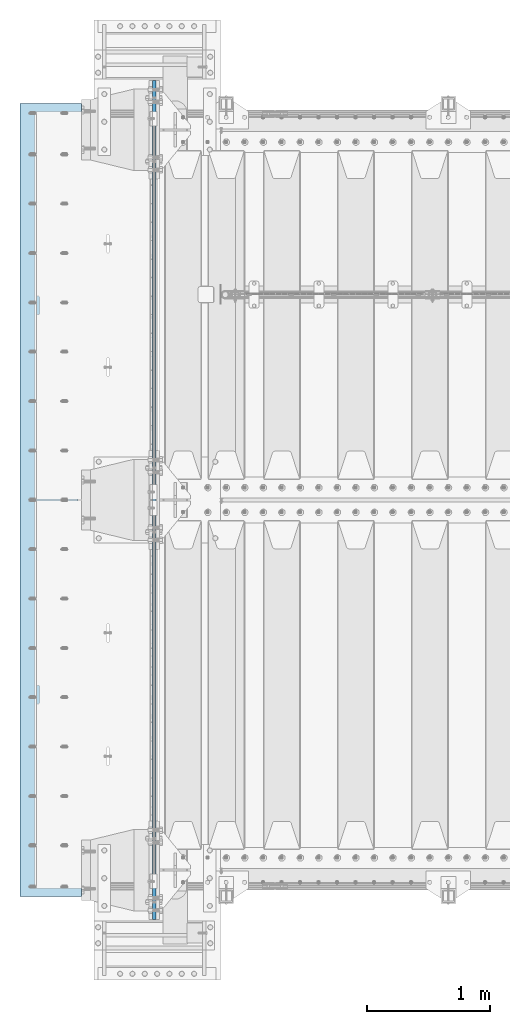
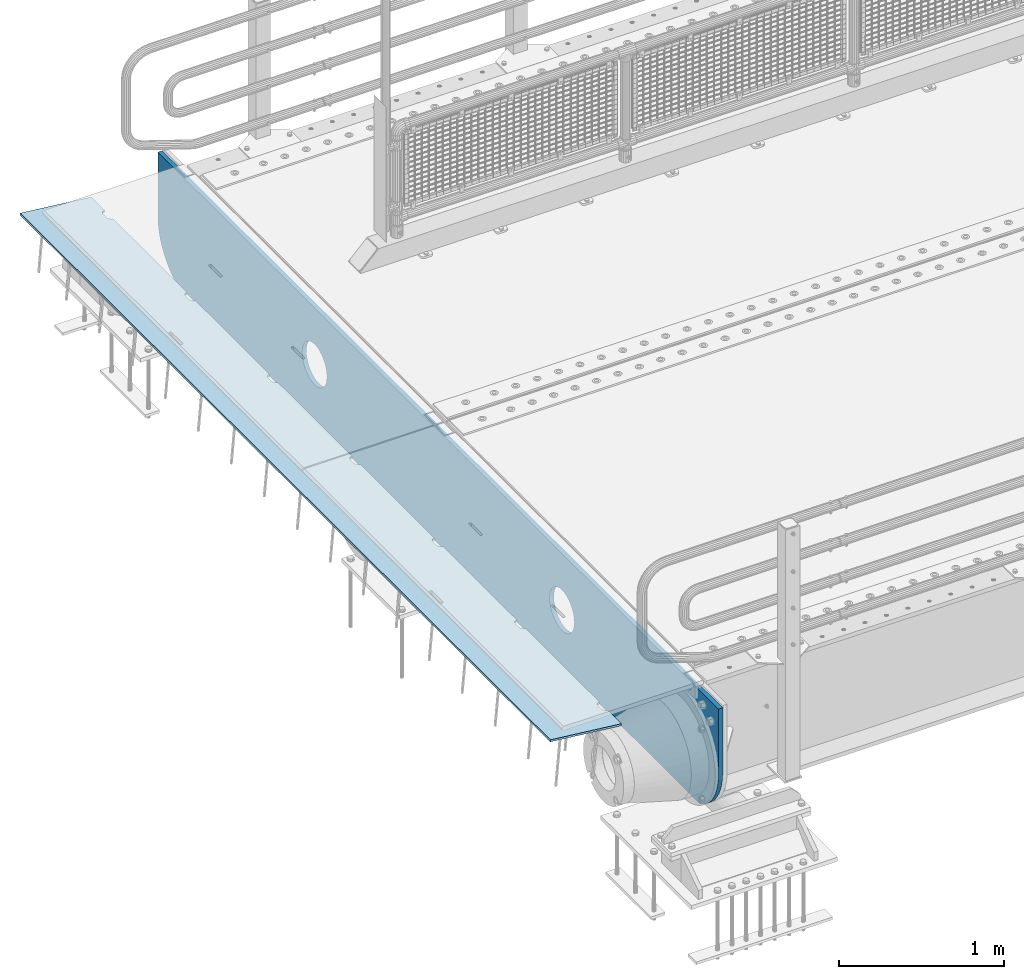
# One storey, part 162 of 208: 2 plates.
"""IFC2X3 building model written with IfcOpenShell, lengths in millimetres."""

from ifc_helpers import new_model, si_unit, frame, origin_with_axes, place, context, subcontext, project, spatial, faceted_brep, material, type_object, element, save


model = new_model("IFC2X3")

# Units and contexts
model_context = context("Model", 3, precision=1e-05, world=origin_with_axes())
body_context = subcontext(model_context, "Body", "Model", "MODEL_VIEW")
ifc_project = project(units=[si_unit("LENGTHUNIT", "METRE", prefix="MILLI"), si_unit("AREAUNIT", "SQUARE_METRE"), si_unit("VOLUMEUNIT", "CUBIC_METRE"), si_unit("MASSUNIT", "GRAM", prefix="KILO"), si_unit("TIMEUNIT", "SECOND"), si_unit("PLANEANGLEUNIT", "RADIAN"), si_unit("SOLIDANGLEUNIT", "STERADIAN"), si_unit("THERMODYNAMICTEMPERATUREUNIT", "DEGREE_CELSIUS"), si_unit("LUMINOUSINTENSITYUNIT", "LUMEN")], contexts=[model_context])

# Site, building, storey
site_placement = place(None, origin_with_axes())
site = spatial("IfcSite", under=ifc_project, at=site_placement, CompositionType="ELEMENT")
building_placement = place(site_placement, origin_with_axes())
building = spatial("IfcBuilding", under=site, at=building_placement, Name="Standard", CompositionType="ELEMENT")
storey_placement = place(building_placement, origin_with_axes())
storey = spatial("IfcBuildingStorey", under=building, at=storey_placement, Name="Undefined", CompositionType="ELEMENT", Elevation=0.0)

# Plates
ifc_material = material(Name="STEEL/S355N")
plate_type_1 = type_object("IfcPlateType", PredefinedType="NOTDEFINED")
plate_1_placement = place(storey_placement, frame((-42485.0, -400.0, -35.999983103574), z_axis=(0.0, 1.0, 0.0), x_axis=(0.0, 0.0, -1.0)))
element("IfcPlate", 1, at=plate_1_placement, inside=storey, type_object=plate_type_1, material=ifc_material, context=body_context, shape_type="Brep", body=[
    faceted_brep([(449.263580019493, -15.0, 2047.11778936592), (449.263580019493, 15.0000000000073, 2047.11778936592), (477.402546520622, 15.0000000000073, 2038.58192701329), (477.402546520622, -15.0, 2038.58192701329), (503.33556653563, 15.0000000000073, 2024.72043882638), (503.33556653563, -15.0, 2024.72043882638), (526.066048648745, 15.0000000000073, 2006.0660140226), (526.066048648745, -15.0, 2006.0660140226), (544.720473179762, 15.0000000000073, 1983.33553168563), (544.720473179762, -15.0, 1983.33553168563), (558.581961055475, 15.0000000000073, 1957.40251150429), (558.581961055475, -15.0, 1957.40251150429), (567.117823070433, 15.0000000000073, 1929.26354490073), (567.117823070433, -15.0, 1929.26354490073), (570.000030834367, 15.0000000000073, 1899.99999658102), (570.000030834367, -15.0, 1899.99999658102), (567.11782271927, 15.0000000000073, 1870.73644829589), (567.11782271927, -15.0, 1870.73644829589), (558.581960366645, 15.0000000000073, 1842.59748179476), (558.581960366645, -15.0, 1842.59748179476), (544.720472179735, 15.0000000000073, 1816.66446177975), (544.720472179735, -15.0, 1816.66446177975), (526.066047375953, 15.0000000000073, 1793.93397966664), (526.066047375953, -15.0, 1793.93397966664), (503.335565038984, 15.0000000000073, 1775.27955513562), (503.335565038984, -15.0, 1775.27955513562), (477.402544857639, 15.0000000000073, 1761.41806725991), (477.402544857639, -15.0, 1761.41806725991), (449.263578254079, 15.0000000000073, 1752.88220524495), (449.263578254079, -15.0, 1752.88220524495), (420.000029934367, 15.0000000000073, 1749.99999748102), (420.000029934367, -15.0, 1749.99999748102), (390.736481649241, 15.0000000000073, 1752.88220559611), (390.736481649241, -15.0, 1752.88220559611), (362.597515148112, 15.0000000000073, 1761.41806794874), (362.597515148112, -15.0, 1761.41806794874), (336.664495133104, 15.0000000000073, 1775.27955613565), (336.664495133104, -15.0, 1775.27955613565), (313.934013019988, 15.0000000000073, 1793.93398093943), (313.934013019988, -15.0, 1793.93398093943), (295.279588488972, 15.0000000000073, 1816.6644632764), (295.279588488972, -15.0, 1816.6644632764), (281.418100613259, 15.0000000000073, 1842.59748345774), (281.418100613259, -15.0, 1842.59748345774), (272.882238598301, 15.0000000000073, 1870.7364500613), (272.882238598301, -15.0, 1870.7364500613), (270.000030834367, 15.0000000000073, 1899.99999838101), (270.000030834367, -15.0, 1899.99999838101), (272.882238949463, 15.0000000000073, 1929.26354666614), (272.882238949463, -15.0, 1929.26354666614), (281.418101302089, 15.0000000000073, 1957.40251316727), (281.418101302089, -15.0, 1957.40251316727), (295.279589488998, 15.0000000000073, 1983.33553318228), (295.279589488998, -15.0, 1983.33553318228), (313.934014292781, 15.0000000000073, 2006.06601529539), (313.934014292781, -15.0, 2006.06601529539), (336.664496629749, 15.0000000000073, 2024.72043982641), (336.664496629749, -15.0, 2024.72043982641), (362.597516811095, 15.0000000000073, 2038.58192770212), (362.597516811095, -15.0, 2038.58192770212), (390.736483414654, 15.0000000000073, 2047.11778971708), (390.736483414654, -15.0, 2047.11778971708), (420.000031734367, 15.0000000000073, 2049.99999748101), (420.000031734367, -15.0, 2049.99999748101), (-9.73069049337028e-07, 15.0, 6800.0), (-9.73069049337028e-07, -15.0, 6800.0), (479.000057686541, -15.0, 6799.9999971271), (479.000057656483, 15.0, 6800.0), (0.0, -15.0, 0.0), (0.0, 15.0, 0.0), (478.999999999949, 15.0, -7.38964445190504e-13), (478.999999999949, -15.0, -7.38964445190504e-13), (527.214672102027, 15.0000000000073, 2.91645036077398), (527.214672102027, -15.0, 2.91645036077398), (574.726265714921, 15.0000000000073, 11.6232730295747), (574.726265714921, -15.0, 11.6232730295747), (620.841954816912, 15.0000000000073, 25.9935029258299), (620.841954816912, -15.0, 25.9935029258299), (664.889268817405, 15.0000000000073, 45.8175897387123), (664.889268817405, -15.0, 45.8175897387123), (706.22589869236, 15.0000000000073, 70.8064536425332), (706.22589869236, -15.0, 70.8064536425332), (744.249063296216, 15.0000000000073, 100.595700731555), (744.249063296216, -15.0, 100.595700731555), (778.404299268338, 15.0000000000073, 134.750936703678), (778.404299268338, -15.0, 134.750936703678), (808.19354635736, 15.0000000000073, 172.774101307533), (808.19354635736, -15.0, 172.774101307533), (833.182410261182, 15.0000000000073, 214.110731182489), (833.182410261182, -15.0, 214.110731182489), (838.999997962172, -15.0, 227.03688080086), (838.999997962172, 15.0, 227.036880800861), (838.99994100267, 15.0, 6572.96326468628), (838.99994100267, -15.0, 6572.96326475294), (833.182425765763, 14.9999999999927, 6585.88925446606), (833.182425795763, -14.9999999999927, 6585.88925446606), (808.193562534776, 14.9999999999927, 6627.22588611692), (808.193562564776, -14.9999999999927, 6627.22588611692), (778.404315788038, 14.9999999999927, 6665.24905247741), (778.404315818038, -14.9999999999927, 6665.24905247741), (744.24907984373, 14.9999999999927, 6699.40429013438), (744.24907987373, -14.9999999999927, 6699.40429013438), (706.225914976979, 14.9999999999927, 6729.19353878774), (706.225915006979, -14.9999999999927, 6729.19353878774), (664.889284579151, 14.9999999999927, 6754.18240409149), (664.889284609151, -14.9999999999927, 6754.18240409149), (620.841969832677, 14.9999999999927, 6774.00649210181), (620.841969862677, -14.9999999999927, 6774.00649210181), (574.726279803637, 14.9999999999927, 6788.37672296152), (574.726279833637, -14.9999999999927, 6788.37672296152), (527.214685128769, 14.9999999999927, 6797.08354633558), (527.214685158768, -14.9999999999927, 6797.08354633558), (477.402561971195, -15.0, 5038.58192701329), (503.335581986203, -15.0, 5024.72043882638), (526.066064099318, -15.0, 5006.0660140226), (544.720488630335, -15.0, 4983.33553168563), (558.581976506048, -15.0, 4957.40251150429), (567.117838521005, -15.0, 4929.26354490073), (570.00004628494, -15.0, 4899.99999658101), (567.117838169843, -15.0, 4870.73644829589), (558.581975817217, -15.0, 4842.59748179476), (544.720487630308, -15.0, 4816.66446177975), (526.066062826526, -15.0, 4793.93397966664), (503.335580489557, -15.0, 4775.27955513562), (477.402560308211, -15.0, 4761.41806725991), (449.263593704652, -15.0, 4752.88220524495), (420.00004538494, -15.0, 4749.99999748101), (390.736497099814, -15.0, 4752.88220559611), (362.597530598685, -15.0, 4761.41806794874), (336.664510583677, -15.0, 4775.27955613565), (313.934028470561, -15.0, 4793.93398093943), (295.279603939545, -15.0, 4816.6644632764), (281.418116063832, -15.0, 4842.59748345774), (272.882254048874, -15.0, 4870.7364500613), (270.00004628494, -15.0, 4899.99999838101), (272.882254400036, -15.0, 4929.26354666614), (281.418116752662, -15.0, 4957.40251316727), (295.279604939571, -15.0, 4983.33553318228), (313.934029743354, -15.0, 5006.06601529539), (336.664512080322, -15.0, 5024.72043982641), (362.597532261668, -15.0, 5038.58192770212), (390.736498865227, -15.0, 5047.11778971708), (420.00004718494, -15.0, 5049.99999748101), (449.263595470066, -15.0, 5047.11778936592), (362.597532261668, 15.0, 5038.58192770212), (390.736498865227, 15.0, 5047.11778971708), (336.664512080322, 15.0, 5024.72043982641), (313.934029743354, 15.0, 5006.06601529539), (295.279604939571, 15.0, 4983.33553318228), (281.418116752662, 15.0, 4957.40251316727), (272.882254400036, 15.0, 4929.26354666614), (270.00004628494, 15.0, 4899.99999838101), (272.882254048874, 15.0, 4870.7364500613), (281.418116063832, 15.0, 4842.59748345774), (295.279603939545, 15.0, 4816.6644632764), (313.934028470561, 15.0, 4793.93398093943), (336.664510583677, 15.0, 4775.27955613565), (362.597530598685, 15.0, 4761.41806794874), (390.736497099814, 15.0, 4752.88220559611), (420.00004538494, 15.0, 4749.99999748101), (449.263593704652, 15.0, 4752.88220524495), (477.402560308211, 15.0, 4761.41806725991), (503.335580489557, 15.0, 4775.27955513562), (526.066062826526, 15.0, 4793.93397966664), (544.720487630308, 15.0, 4816.66446177975), (558.581975817217, 15.0, 4842.59748179476), (567.117838169843, 15.0, 4870.73644829589), (570.00004628494, 15.0, 4899.99999658101), (567.117838521005, 15.0, 4929.26354490073), (558.581976506048, 15.0, 4957.40251150429), (544.720488630335, 15.0, 4983.33553168563), (526.066064099318, 15.0, 5006.0660140226), (503.335581986203, 15.0, 5024.72043882638), (477.402561971195, 15.0, 5038.58192701329), (449.263595470066, 15.0, 5047.11778936592), (420.00004718494, 15.0, 5049.99999748101)], [[[0, 1, 2, 3]], [[3, 2, 4, 5]], [[5, 4, 6, 7]], [[7, 6, 8, 9]], [[9, 8, 10, 11]], [[11, 10, 12, 13]], [[13, 12, 14, 15]], [[15, 14, 16, 17]], [[17, 16, 18, 19]], [[19, 18, 20, 21]], [[21, 20, 22, 23]], [[23, 22, 24, 25]], [[25, 24, 26, 27]], [[27, 26, 28, 29]], [[29, 28, 30, 31]], [[31, 30, 32, 33]], [[33, 32, 34, 35]], [[35, 34, 36, 37]], [[37, 36, 38, 39]], [[39, 38, 40, 41]], [[41, 40, 42, 43]], [[43, 42, 44, 45]], [[45, 44, 46, 47]], [[47, 46, 48, 49]], [[49, 48, 50, 51]], [[51, 50, 52, 53]], [[53, 52, 54, 55]], [[55, 54, 56, 57]], [[57, 56, 58, 59]], [[59, 58, 60, 61]], [[61, 60, 62, 63]], [[63, 62, 1, 0]], [[64, 65, 66, 67]], [[68, 65, 64, 69]], [[68, 69, 70, 71]], [[71, 70, 72, 73]], [[73, 72, 74, 75]], [[75, 74, 76, 77]], [[77, 76, 78, 79]], [[79, 78, 80, 81]], [[81, 80, 82, 83]], [[83, 82, 84, 85]], [[85, 84, 86, 87]], [[87, 86, 88, 89]], [[90, 89, 88, 91]], [[90, 91, 92, 93]], [[93, 92, 94, 95]], [[95, 94, 96, 97]], [[97, 96, 98, 99]], [[99, 98, 100, 101]], [[101, 100, 102, 103]], [[103, 102, 104, 105]], [[105, 104, 106, 107]], [[107, 106, 108, 109]], [[109, 108, 110, 111]], [[66, 111, 110, 67]], [[65, 68, 71, 73, 75, 77, 79, 81, 83, 85, 87, 89, 90, 93, 95, 97, 99, 101, 103, 105, 107, 109, 111, 66], [3, 5, 7, 9, 11, 13, 15, 17, 19, 21, 23, 25, 27, 29, 31, 33, 35, 37, 39, 41, 43, 45, 47, 49, 51, 53, 55, 57, 59, 61, 63, 0], [112, 113, 114, 115, 116, 117, 118, 119, 120, 121, 122, 123, 124, 125, 126, 127, 128, 129, 130, 131, 132, 133, 134, 135, 136, 137, 138, 139, 140, 141, 142, 143]], [[140, 144, 145, 141]], [[139, 146, 144, 140]], [[138, 147, 146, 139]], [[137, 148, 147, 138]], [[136, 149, 148, 137]], [[135, 150, 149, 136]], [[134, 151, 150, 135]], [[133, 152, 151, 134]], [[132, 153, 152, 133]], [[131, 154, 153, 132]], [[130, 155, 154, 131]], [[129, 156, 155, 130]], [[128, 157, 156, 129]], [[127, 158, 157, 128]], [[126, 159, 158, 127]], [[125, 160, 159, 126]], [[124, 161, 160, 125]], [[123, 162, 161, 124]], [[122, 163, 162, 123]], [[121, 164, 163, 122]], [[120, 165, 164, 121]], [[119, 166, 165, 120]], [[118, 167, 166, 119]], [[117, 168, 167, 118]], [[116, 169, 168, 117]], [[115, 170, 169, 116]], [[114, 171, 170, 115]], [[113, 172, 171, 114]], [[112, 173, 172, 113]], [[143, 174, 173, 112]], [[142, 175, 174, 143]], [[141, 145, 175, 142]], [[108, 106, 104, 102, 100, 98, 96, 94, 92, 91, 88, 86, 84, 82, 80, 78, 76, 74, 72, 70, 69, 64, 67, 110], [58, 56, 54, 52, 50, 48, 46, 44, 42, 40, 38, 36, 34, 32, 30, 28, 26, 24, 22, 20, 18, 16, 14, 12, 10, 8, 6, 4, 2, 1, 62, 60], [144, 146, 147, 148, 149, 150, 151, 152, 153, 154, 155, 156, 157, 158, 159, 160, 161, 162, 163, 164, 165, 166, 167, 168, 169, 170, 171, 172, 173, 174, 175, 145]]]),
])
plate_type_2 = type_object("IfcPlateType", PredefinedType="NOTDEFINED")
plate_2_placement = place(storey_placement, frame((-43074.1812549702, -214.999999999995, -62.544823504668), z_axis=(-0.994023532708189, -3.99999998872671e-09, 0.109166003967953), x_axis=(0.0, 1.0, 0.0)))
element("IfcPlate", 2, at=plate_2_placement, inside=storey, type_object=plate_type_2, material=ifc_material, context=body_context, shape_type="Brep", body=[
    faceted_brep([(6164.99999999665, -7.49999999999909, 7.33479246264324e-05), (6165.00000000327, 7.50000000000091, -2.18278728425503e-11), (6165.45576743374, 7.50000000000091, 5.20976320983755), (6165.45576742719, -7.49999999999909, 5.20976320983755), (6166.80922142074, 7.50000000000091, 10.2609221742096), (6166.80922141419, -7.49999999999727, 10.2609221742168), (6169.01923794974, 7.5, 15.0003178656625), (6169.01923794319, -7.49999999999818, 15.0003178656625), (6172.01866678684, 7.50000000000091, 19.2839461443364), (6172.01866678029, -7.49999999999818, 19.2839461443364), (6175.7163718046, 7.50000000000091, 22.9816511325989), (6175.71637179805, -7.49999999999727, 22.9816511325989), (6180.00000010719, 7.50000000000091, 25.9810799355328), (6180.00000010064, -7.49999999999818, 25.98107993554), (6184.73939581626, 7.50000000000091, 28.1910964267299), (6184.73939580971, -7.49999999999727, 28.1910964267299), (6189.79055479144, 7.50000000000091, 29.5445503734445), (6189.79055478489, -7.49999999999727, 29.5445503734445), (6195.00000012327, 7.50000000000091, 30.0003177623585), (6195.00000011672, -7.49999999999727, 30.0003177623657), (6235.00000012327, 7.50000000000182, 30.0003176033133), (6235.00000011672, -7.49999999999636, 30.0003176033133), (6240.20944545146, 7.5, 29.54455017297), (6240.20944544491, -7.49999999999818, 29.54455017297), (6245.2606044158, 7.50000000000091, 28.1910961860995), (6245.26060440926, -7.49999999999727, 28.1910961860922), (6250.00000010719, 7.5, 25.9810796571983), (6250.00000010064, -7.49999999999818, 25.9810796572056), (6254.28362838579, 7.50000000000091, 22.9816508202057), (6254.28362837924, -7.49999999999818, 22.981650820213), (6257.98133337397, 7.50000000000091, 19.283945802541), (6257.98133336743, -7.49999999999727, 19.2839458025337), (6260.98076217681, 7.50000000000091, 15.0003175000093), (6260.98076217025, -7.49999999999818, 15.0003175000093), (6263.19077866789, 7.50000000000091, 10.2609217909994), (6263.19077866134, -7.49999999999727, 10.2609217909921), (6264.54423261448, 7.50000000000091, 5.20976281585172), (6264.54423260793, -7.49999999999818, 5.20976281585172), (6264.99999999672, -7.5, 0.000317484031256754), (6265.00000000327, 7.5, -2.18278728425503e-11), (5264.99999999672, -7.5, 0.000322454179695342), (5264.54423260793, -7.50000000000182, 5.20976778599288), (5264.54423261448, 7.50000000000364, 5.20976778599288), (5265.00000000327, 7.50000000000091, -2.18278728425503e-11), (5263.19077866134, -7.5, 10.2609267611406), (5263.19077866789, 7.50000000000273, 10.2609267611333), (5260.98076217025, -7.50000000000091, 15.000322470165), (5260.98076217681, 7.50000000000273, 15.0003224701577), (5257.98133336743, -7.50000000000091, 19.2839507726821), (5257.98133337397, 7.50000000000364, 19.2839507726749), (5254.28362837924, -7.5, 22.9816557903541), (5254.28362838579, 7.50000000000273, 22.9816557903541), (5250.00000010064, -7.50000000000182, 25.9810846273467), (5250.00000010719, 7.50000000000364, 25.9810846273467), (5245.26060440926, -7.50000000000091, 28.1911011562406), (5245.2606044158, 7.50000000000273, 28.1911011562333), (5240.20944544491, -7.5, 29.5445551431185), (5240.20944545146, 7.50000000000364, 29.5445551431112), (5235.00000011672, -7.49999999999909, 30.0003225734617), (5235.00000012327, 7.50000000000364, 30.0003225734545), (5195.00000011672, -7.5, 30.0003227324996), (5195.00000012327, 7.50000000000273, 30.0003227324996), (5189.79055478489, -7.5, 29.5445553435857), (5189.79055479144, 7.50000000000364, 29.5445553435857), (5184.73939580971, -7.50000000000091, 28.1911013968711), (5184.73939581626, 7.50000000000273, 28.1911013968711), (5180.00000010064, -7.50000000000182, 25.9810849056812), (5180.00000010719, 7.50000000000455, 25.9810849056812), (5175.71637179805, -7.5, 22.9816561027474), (5175.7163718046, 7.50000000000364, 22.9816561027401), (5172.01866678029, -7.50000000000182, 19.2839511144703), (5172.01866678684, 7.50000000000364, 19.2839511144703), (5169.01923794319, -7.50000000000091, 15.0003228358037), (5169.01923794974, 7.50000000000364, 15.0003228357964), (5166.80922141419, -7.50000000000091, 10.2609271443653), (5166.80922142074, 7.50000000000273, 10.2609271443653), (5165.45576742719, -7.50000000000091, 5.20976817997871), (5165.45576743374, 7.50000000000455, 5.20976817997143), (5164.9999999967, -7.49999999999909, 0.000191312581591774), (5165.00000000327, 7.50000000000091, -2.18278728425503e-11), (4264.99999999672, -7.5, 0.000327424320857972), (4265.00000000327, 7.5, -1.45519152283669e-11), (4264.54423260793, -7.49999999999909, 5.20977275614132), (4264.54423261448, 7.50000000000273, 5.20977275614132), (4263.19077866134, -7.50000000000091, 10.2609317312817), (4263.19077866789, 7.50000000000273, 10.2609317312817), (4260.98076217025, -7.5, 15.0003274402989), (4260.98076217681, 7.50000000000364, 15.0003274402989), (4257.98133336742, -7.5, 19.2839557428233), (4257.98133337397, 7.50000000000273, 19.2839557428233), (4254.28362837924, -7.49999999999909, 22.9816607605026), (4254.28362838579, 7.50000000000455, 22.9816607604953), (4250.00000010064, -7.49999999999909, 25.9810895974952), (4250.00000010719, 7.50000000000273, 25.9810895974879), (4245.26060440925, -7.49999999999909, 28.1911061263818), (4245.2606044158, 7.50000000000455, 28.1911061263891), (4240.20944544491, -7.49999999999818, 29.5445601132596), (4240.20944545146, 7.50000000000455, 29.5445601132596), (4235.00000011672, -7.5, 30.0003275436029), (4235.00000012327, 7.50000000000273, 30.0003275436029), (4195.00000011672, -7.5, 30.0003277026481), (4195.00000012327, 7.50000000000364, 30.0003277026408), (4189.79055478489, -7.5, 29.5445603137268), (4189.79055479144, 7.50000000000455, 29.5445603137268), (4184.73939580971, -7.5, 28.1911063670195), (4184.73939581626, 7.50000000000364, 28.1911063670195), (4180.00000010064, -7.5, 25.9810898758224), (4180.00000010719, 7.50000000000364, 25.9810898758224), (4175.71637179805, -7.5, 22.9816610728813), (4175.7163718046, 7.50000000000364, 22.9816610728813), (4172.01866678029, -7.5, 19.2839560846187), (4172.01866678684, 7.50000000000364, 19.2839560846187), (4169.01923794319, -7.5, 15.0003278059448), (4169.01923794974, 7.50000000000273, 15.0003278059448), (4166.80922141419, -7.5, 10.2609321145064), (4166.80922142074, 7.50000000000455, 10.2609321144992), (4165.45576742719, -7.49999999999909, 5.20977315012715), (4165.45576743374, 7.50000000000273, 5.20977315012715), (4164.99999999671, -7.5, 0.00023787470854586), (4165.00000000327, 7.5, -1.45519152283669e-11), (3264.99999999672, -7.49999999999909, 0.00033239446929656), (3265.00000000327, 7.50000000000091, -7.27595761418343e-12), (3264.54423260793, -7.5, 5.20977772628248), (3264.54423261448, 7.50000000000364, 5.20977772628248), (3263.19077866134, -7.5, 10.2609367014229), (3263.19077866789, 7.50000000000364, 10.2609367014156), (3260.98076217025, -7.5, 15.0003324104473), (3260.98076217681, 7.50000000000364, 15.00033241044), (3257.98133336743, -7.5, 19.2839607129645), (3257.98133337397, 7.50000000000455, 19.2839607129572), (3254.28362837924, -7.5, 22.9816657306365), (3254.28362838579, 7.50000000000364, 22.9816657306365), (3250.00000010064, -7.49999999999909, 25.9810945676363), (3250.00000010719, 7.50000000000364, 25.9810945676363), (3245.26060440925, -7.49999999999909, 28.1911110965229), (3245.2606044158, 7.50000000000455, 28.1911110965157), (3240.20944544491, -7.5, 29.5445650834008), (3240.20944545146, 7.50000000000364, 29.5445650833935), (3235.00000011672, -7.5, 30.0003325137513), (3235.00000012327, 7.50000000000364, 30.0003325137441), (3195.00000011672, -7.49999999999909, 30.0003326727892), (3195.00000012327, 7.50000000000546, 30.0003326727892), (3189.79055478489, -7.5, 29.544565283868), (3189.79055479144, 7.50000000000364, 29.544565283868), (3184.73939580971, -7.5, 28.1911113371607), (3184.73939581626, 7.50000000000364, 28.191111337168), (3180.00000010064, -7.49999999999909, 25.9810948459635), (3180.00000010719, 7.50000000000455, 25.9810948459635), (3175.71637179805, -7.5, 22.981666043037), (3175.7163718046, 7.50000000000273, 22.981666043037), (3172.01866678029, -7.49999999999909, 19.2839610547526), (3172.01866678684, 7.50000000000455, 19.2839610547526), (3169.01923794319, -7.5, 15.000332776086), (3169.01923794974, 7.50000000000455, 15.0003327760787), (3166.80922141419, -7.49999999999909, 10.2609370846403), (3166.80922142074, 7.50000000000364, 10.2609370846403), (3165.45576742719, -7.5, 5.20977812026103), (3165.45576743374, 7.50000000000364, 5.20977812026831), (3164.99999999672, -7.50000000000091, 0.000264464681094978), (3165.00000000327, 7.49999999999909, -1.45519152283669e-11), (2264.99999999672, -7.5, 0.000337364603183232), (2265.00000000327, 7.50000000000091, -7.27595761418343e-12), (2264.54423260793, -7.49999999999818, 5.20978269642364), (2264.54423261448, 7.50000000000182, 5.20978269642364), (2263.19077866134, -7.49999999999818, 10.2609416715786), (2263.19077866789, 7.50000000000364, 10.2609416715786), (2260.98076217025, -7.49999999999818, 15.0003373805885), (2260.9807621768, 7.50000000000273, 15.0003373805885), (2257.98133336743, -7.49999999999727, 19.2839656831129), (2257.98133337398, 7.50000000000364, 19.2839656831129), (2254.28362837924, -7.49999999999909, 22.9816707007849), (2254.28362838579, 7.50000000000182, 22.9816707007776), (2250.00000010064, -7.49999999999727, 25.9810995377848), (2250.00000010719, 7.50000000000364, 25.981099537792), (2245.26060440925, -7.49999999999818, 28.1911160666714), (2245.2606044158, 7.50000000000273, 28.1911160666714), (2240.20944544491, -7.49999999999818, 29.5445700535493), (2240.20944545146, 7.50000000000273, 29.5445700535493), (2235.00000011672, -7.49999999999818, 30.0003374838852), (2235.00000012327, 7.50000000000273, 30.0003374838852), (2195.00000011672, -7.49999999999818, 30.0003376429377), (2195.00000012327, 7.50000000000273, 30.0003376429304), (2189.79055478489, -7.49999999999818, 29.5445702540164), (2189.79055479144, 7.50000000000182, 29.5445702540164), (2184.73939580971, -7.49999999999818, 28.1911163073091), (2184.73939581626, 7.50000000000273, 28.1911163073091), (2180.00000010064, -7.49999999999818, 25.981099816112), (2180.00000010719, 7.50000000000273, 25.9810998161047), (2175.71637179805, -7.49999999999818, 22.9816710131709), (2175.7163718046, 7.50000000000273, 22.9816710131709), (2172.01866678029, -7.49999999999727, 19.2839660249083), (2172.01866678684, 7.50000000000182, 19.2839660249083), (2169.01923794319, -7.49999999999909, 15.0003377462417), (2169.01923794974, 7.50000000000273, 15.0003377462417), (2166.80922141419, -7.49999999999818, 10.2609420547888), (2166.80922142074, 7.50000000000273, 10.2609420547888), (2165.45576742719, -7.49999999999818, 5.20978309040947), (2165.45576743374, 7.50000000000182, 5.20978309040947), (2164.99999999672, -7.5, 0.000282683002296835), (2165.00000000327, 7.50000000000091, -7.27595761418343e-12), (1264.99999999672, -7.5, 0.00034233475162182), (1265.00000000327, 7.5, 0.0), (1264.54423260793, -7.49999999999909, 5.20978766657208), (1264.54423261448, 7.50000000000182, 5.20978766656481), (1263.19077866134, -7.49999999999818, 10.2609466417125), (1263.19077866789, 7.50000000000091, 10.2609466417052), (1260.98076217025, -7.49999999999909, 15.0003423507369), (1260.9807621768, 7.50000000000091, 15.0003423507369), (1257.98133336743, -7.49999999999818, 19.2839706532541), (1257.98133337398, 7.50000000000091, 19.2839706532541), (1254.28362837924, -7.49999999999818, 22.9816756709261), (1254.28362838579, 7.50000000000182, 22.9816756709261), (1250.00000010064, -7.49999999999818, 25.9811045079186), (1250.00000010719, 7.50000000000182, 25.9811045079186), (1245.26060440925, -7.49999999999818, 28.1911210368125), (1245.2606044158, 7.50000000000091, 28.1911210368125), (1240.20944544491, -7.49999999999909, 29.5445750236904), (1240.20944545146, 7.50000000000091, 29.5445750236831), (1235.00000011672, -7.49999999999818, 30.0003424540337), (1235.00000012327, 7.50000000000182, 30.0003424540264), (1195.00000011672, -7.49999999999818, 30.0003426130716), (1195.00000012327, 7.50000000000182, 30.0003426130716), (1189.79055478489, -7.49999999999818, 29.5445752241576), (1189.79055479144, 7.50000000000091, 29.5445752241576), (1184.73939580971, -7.49999999999909, 28.191121277443), (1184.73939581626, 7.50000000000182, 28.1911212774503), (1180.00000010064, -7.49999999999727, 25.9811047862531), (1180.00000010719, 7.50000000000182, 25.9811047862531), (1175.71637179805, -7.49999999999818, 22.9816759833193), (1175.7163718046, 7.50000000000182, 22.9816759833193), (1172.01866678029, -7.49999999999909, 19.2839709950495), (1172.01866678684, 7.50000000000091, 19.2839709950495), (1169.01923794319, -7.49999999999818, 15.0003427163756), (1169.01923794974, 7.50000000000182, 15.0003427163683), (1166.80922141419, -7.49999999999818, 10.2609470249372), (1166.80922142074, 7.50000000000182, 10.2609470249372), (1165.45576742719, -7.49999999999818, 5.20978806055064), (1165.45576743374, 7.50000000000182, 5.20978806055791), (1164.99999999672, -7.49999999999909, 0.000296603444439825), (1165.00000000327, 7.50000000000091, 0.0), (264.999999996721, -7.5, 0.000347304885508493), (265.000000003271, 7.50000000000091, 0.0), (264.544232607925, -7.49999999999909, 5.20979263671325), (264.544232614475, 7.50000000000091, 5.20979263671325), (263.190778661341, -7.5, 10.2609516118537), (263.190778667891, 7.5, 10.2609516118537), (260.980762170255, -7.49999999999909, 15.0003473208708), (260.980762176805, 7.50000000000091, 15.0003473208708), (257.981333367425, -7.5, 19.2839756233952), (257.981333373975, 7.5, 19.2839756233952), (254.283628379243, -7.5, 22.9816806410745), (254.283628385793, 7.50000000000091, 22.9816806410745), (250.000000100644, -7.5, 25.9811094780671), (250.000000107194, 7.50000000000091, 25.9811094780744), (245.260604409255, -7.5, 28.1911260069537), (245.260604415805, 7.5, 28.1911260069537), (240.209445444906, -7.49999999999909, 29.5445799938316), (240.209445451456, 7.5, 29.5445799938316), (235.000000116721, -7.5, 30.0003474241748), (235.000000123271, 7.5, 30.0003474241748), (195.000000116721, -7.5, 30.00034758322), (195.000000123271, 7.5, 30.00034758322), (189.79055478489, -7.5, 29.544580194306), (189.79055479144, 7.5, 29.5445801942988), (184.739395809714, -7.49999999999909, 28.1911262475987), (184.739395816264, 7.50000000000091, 28.1911262475915), (180.000000100644, -7.49999999999909, 25.9811097563943), (180.000000107194, 7.50000000000091, 25.9811097563943), (175.71637179805, -7.49999999999909, 22.9816809534605), (175.7163718046, 7.5, 22.9816809534605), (172.018666780286, -7.49999999999909, 19.2839759651906), (172.018666786836, 7.50000000000091, 19.2839759651906), (169.019237943188, -7.5, 15.0003476865168), (169.019237949738, 7.50000000000091, 15.0003476865168), (166.809221414186, -7.49999999999909, 10.2609519950784), (166.809221420736, 7.5, 10.2609519950856), (165.455767427193, -7.49999999999909, 5.20979303069907), (165.455767433743, 7.50000000000091, 5.2097930306918), (164.999999996721, -7.49999999999909, 7.27595761418343e-12), (165.000000003271, 7.50000000000182, 1.45519152283669e-11), (0.0, -7.5, -4.54747350886464e-13), (0.0, 7.5, -4.54747350886464e-13), (1.72945934195923e-06, -7.49999999999909, 500.002441406257), (1.72945928511581e-06, 7.50000000000091, 500.002441406257), (6430.00000001195, -7.49999999999909, 500.002380371094), (6430.00000001195, 7.50000000000091, 500.002380371094), (6430.0, -7.5, -2.91038304567337e-11), (6430.0, 7.50000000000091, -2.18278728425503e-11)], [[[0, 1, 2, 3]], [[3, 2, 4, 5]], [[5, 4, 6, 7]], [[7, 6, 8, 9]], [[9, 8, 10, 11]], [[11, 10, 12, 13]], [[13, 12, 14, 15]], [[15, 14, 16, 17]], [[17, 16, 18, 19]], [[19, 18, 20, 21]], [[21, 20, 22, 23]], [[23, 22, 24, 25]], [[25, 24, 26, 27]], [[27, 26, 28, 29]], [[29, 28, 30, 31]], [[31, 30, 32, 33]], [[33, 32, 34, 35]], [[35, 34, 36, 37]], [[38, 37, 36, 39]], [[40, 41, 42, 43]], [[44, 45, 42, 41]], [[46, 47, 45, 44]], [[48, 49, 47, 46]], [[50, 51, 49, 48]], [[52, 53, 51, 50]], [[54, 55, 53, 52]], [[56, 57, 55, 54]], [[58, 59, 57, 56]], [[60, 61, 59, 58]], [[62, 63, 61, 60]], [[64, 65, 63, 62]], [[66, 67, 65, 64]], [[68, 69, 67, 66]], [[70, 71, 69, 68]], [[72, 73, 71, 70]], [[74, 75, 73, 72]], [[76, 77, 75, 74]], [[78, 79, 77, 76]], [[80, 81, 79, 78]], [[80, 82, 83, 81]], [[84, 85, 83, 82]], [[86, 87, 85, 84]], [[88, 89, 87, 86]], [[90, 91, 89, 88]], [[92, 93, 91, 90]], [[94, 95, 93, 92]], [[96, 97, 95, 94]], [[98, 99, 97, 96]], [[100, 101, 99, 98]], [[102, 103, 101, 100]], [[104, 105, 103, 102]], [[106, 107, 105, 104]], [[108, 109, 107, 106]], [[110, 111, 109, 108]], [[112, 113, 111, 110]], [[114, 115, 113, 112]], [[116, 117, 115, 114]], [[118, 119, 117, 116]], [[120, 121, 119, 118]], [[120, 122, 123, 121]], [[124, 125, 123, 122]], [[126, 127, 125, 124]], [[128, 129, 127, 126]], [[130, 131, 129, 128]], [[132, 133, 131, 130]], [[134, 135, 133, 132]], [[136, 137, 135, 134]], [[138, 139, 137, 136]], [[140, 141, 139, 138]], [[142, 143, 141, 140]], [[144, 145, 143, 142]], [[146, 147, 145, 144]], [[148, 149, 147, 146]], [[150, 151, 149, 148]], [[152, 153, 151, 150]], [[154, 155, 153, 152]], [[156, 157, 155, 154]], [[158, 159, 157, 156]], [[160, 161, 159, 158]], [[160, 162, 163, 161]], [[164, 165, 163, 162]], [[166, 167, 165, 164]], [[168, 169, 167, 166]], [[170, 171, 169, 168]], [[172, 173, 171, 170]], [[174, 175, 173, 172]], [[176, 177, 175, 174]], [[178, 179, 177, 176]], [[180, 181, 179, 178]], [[182, 183, 181, 180]], [[184, 185, 183, 182]], [[186, 187, 185, 184]], [[188, 189, 187, 186]], [[190, 191, 189, 188]], [[192, 193, 191, 190]], [[194, 195, 193, 192]], [[196, 197, 195, 194]], [[198, 199, 197, 196]], [[200, 201, 199, 198]], [[200, 202, 203, 201]], [[204, 205, 203, 202]], [[206, 207, 205, 204]], [[208, 209, 207, 206]], [[210, 211, 209, 208]], [[212, 213, 211, 210]], [[214, 215, 213, 212]], [[216, 217, 215, 214]], [[218, 219, 217, 216]], [[220, 221, 219, 218]], [[222, 223, 221, 220]], [[224, 225, 223, 222]], [[226, 227, 225, 224]], [[228, 229, 227, 226]], [[230, 231, 229, 228]], [[232, 233, 231, 230]], [[234, 235, 233, 232]], [[236, 237, 235, 234]], [[238, 239, 237, 236]], [[240, 241, 239, 238]], [[240, 242, 243, 241]], [[244, 245, 243, 242]], [[246, 247, 245, 244]], [[248, 249, 247, 246]], [[250, 251, 249, 248]], [[252, 253, 251, 250]], [[254, 255, 253, 252]], [[256, 257, 255, 254]], [[258, 259, 257, 256]], [[260, 261, 259, 258]], [[262, 263, 261, 260]], [[264, 265, 263, 262]], [[266, 267, 265, 264]], [[268, 269, 267, 266]], [[270, 271, 269, 268]], [[272, 273, 271, 270]], [[274, 275, 273, 272]], [[276, 277, 275, 274]], [[278, 279, 277, 276]], [[280, 281, 279, 278]], [[280, 282, 283, 281]], [[282, 284, 285, 283]], [[284, 286, 287, 285]], [[287, 286, 38, 39]], [[34, 32, 30, 28, 26, 24, 22, 20, 18, 16, 14, 12, 10, 8, 6, 4, 2, 1, 43, 42, 45, 47, 49, 51, 53, 55, 57, 59, 61, 63, 65, 67, 69, 71, 73, 75, 77, 79, 81, 83, 85, 87, 89, 91, 93, 95, 97, 99, 101, 103, 105, 107, 109, 111, 113, 115, 117, 119, 121, 123, 125, 127, 129, 131, 133, 135, 137, 139, 141, 143, 145, 147, 149, 151, 153, 155, 157, 159, 161, 163, 165, 167, 169, 171, 173, 175, 177, 179, 181, 183, 185, 187, 189, 191, 193, 195, 197, 199, 201, 203, 205, 207, 209, 211, 213, 215, 217, 219, 221, 223, 225, 227, 229, 231, 233, 235, 237, 239, 241, 243, 245, 247, 249, 251, 253, 255, 257, 259, 261, 263, 265, 267, 269, 271, 273, 275, 277, 279, 281, 283, 285, 287, 39, 36]], [[40, 43, 1, 0]], [[286, 284, 282, 280, 278, 276, 274, 272, 270, 268, 266, 264, 262, 260, 258, 256, 254, 252, 250, 248, 246, 244, 242, 240, 238, 236, 234, 232, 230, 228, 226, 224, 222, 220, 218, 216, 214, 212, 210, 208, 206, 204, 202, 200, 198, 196, 194, 192, 190, 188, 186, 184, 182, 180, 178, 176, 174, 172, 170, 168, 166, 164, 162, 160, 158, 156, 154, 152, 150, 148, 146, 144, 142, 140, 138, 136, 134, 132, 130, 128, 126, 124, 122, 120, 118, 116, 114, 112, 110, 108, 106, 104, 102, 100, 98, 96, 94, 92, 90, 88, 86, 84, 82, 80, 78, 76, 74, 72, 70, 68, 66, 64, 62, 60, 58, 56, 54, 52, 50, 48, 46, 44, 41, 40, 0, 3, 5, 7, 9, 11, 13, 15, 17, 19, 21, 23, 25, 27, 29, 31, 33, 35, 37, 38]]]),
])

save(model, "model.ifc")
